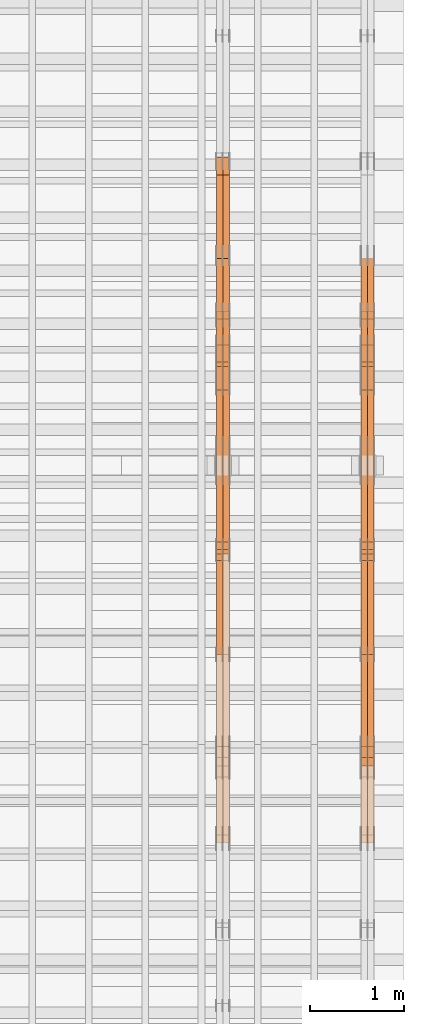
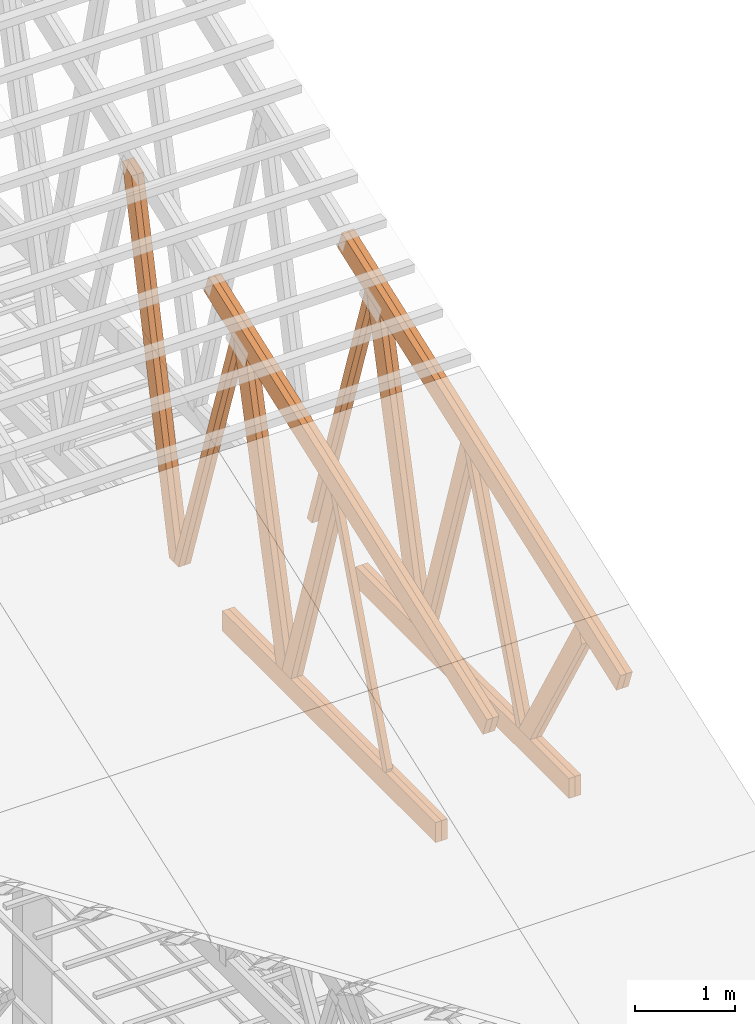
# One storey, part 55 of 189: 27 proxies.
"""IFC2X3 building model written with IfcOpenShell, lengths in millimetres."""

from ifc_helpers import new_model, entity, si_unit, converted_unit, derived_unit, direction, frame, origin, origin_2d_with_axis, place, context, subcontext, project, spatial, polyline, rectangle, outline, extrude, source, transform, mapped, material, type_object, type_shapes, element, save


model = new_model("IFC2X3")

# Units and contexts
model_context = context("Model", 3, precision=0.01, world=origin(), true_north=direction((6.12303176911189e-17, 1.0)))
body_context = subcontext(model_context, "Body", "Model", "MODEL_VIEW")
ifc_project = project(units=[si_unit("LENGTHUNIT", "METRE", prefix="MILLI"), si_unit("AREAUNIT", "SQUARE_METRE"), si_unit("VOLUMEUNIT", "CUBIC_METRE"), converted_unit("PLANEANGLEUNIT", "DEGREE", entity("IfcRatioMeasure", 0.0174532925199433), si_unit("PLANEANGLEUNIT", "RADIAN"), dimensions=[0, 0, 0, 0, 0, 0, 0]), si_unit("MASSUNIT", "GRAM", prefix="KILO"), derived_unit("MASSDENSITYUNIT", [(si_unit("MASSUNIT", "GRAM", prefix="KILO"), 1), (si_unit("LENGTHUNIT", "METRE"), -3)]), si_unit("TIMEUNIT", "SECOND"), si_unit("FREQUENCYUNIT", "HERTZ"), si_unit("THERMODYNAMICTEMPERATUREUNIT", "DEGREE_CELSIUS"), derived_unit("THERMALTRANSMITTANCEUNIT", [(si_unit("MASSUNIT", "GRAM", prefix="KILO"), 1), (si_unit("THERMODYNAMICTEMPERATUREUNIT", "KELVIN"), -1), (si_unit("TIMEUNIT", "SECOND"), -3)]), derived_unit("VOLUMETRICFLOWRATEUNIT", [(si_unit("LENGTHUNIT", "METRE"), 3), (si_unit("TIMEUNIT", "SECOND"), -1)]), si_unit("ELECTRICCURRENTUNIT", "AMPERE"), si_unit("ELECTRICVOLTAGEUNIT", "VOLT"), si_unit("POWERUNIT", "WATT"), si_unit("FORCEUNIT", "NEWTON"), si_unit("ILLUMINANCEUNIT", "LUX"), si_unit("LUMINOUSFLUXUNIT", "LUMEN"), si_unit("LUMINOUSINTENSITYUNIT", "CANDELA"), derived_unit("USERDEFINED", [(si_unit("MASSUNIT", "GRAM", prefix="KILO"), -1), (si_unit("LENGTHUNIT", "METRE"), -2), (si_unit("TIMEUNIT", "SECOND"), 3), (si_unit("LUMINOUSFLUXUNIT", "LUMEN"), 1)]), derived_unit("LINEARVELOCITYUNIT", [(si_unit("LENGTHUNIT", "METRE"), 1), (si_unit("TIMEUNIT", "SECOND"), -1)]), si_unit("PRESSUREUNIT", "PASCAL"), derived_unit("USERDEFINED", [(si_unit("LENGTHUNIT", "METRE"), -2), (si_unit("MASSUNIT", "GRAM", prefix="KILO"), 1), (si_unit("TIMEUNIT", "SECOND"), -2)])], contexts=[model_context])

# Site, building, storey
site_placement = place(None, origin())
site = spatial("IfcSite", under=ifc_project, at=site_placement, CompositionType="ELEMENT")
building_placement = place(site_placement, origin())
building = spatial("IfcBuilding", under=site, at=building_placement, CompositionType="ELEMENT")
storey_placement = place(building_placement, origin())
storey = spatial("IfcBuildingStorey", under=building, at=storey_placement, Name="Default", CompositionType="ELEMENT", Elevation=0.0)

# Proxies
ifc_material_1 = material(Name="IfcSurfaceStyle #273112")
building_element_proxy_type_1 = type_object("IfcBuildingElementProxyType", Name="T1-W7 273110", PredefinedType="NOTDEFINED", material=ifc_material_1)
shared_shape_1 = source(origin(), body_context, "Body", "SweptSolid", [
    extrude(outline(polyline([(-2158.15323194511, -47.5001976605119), (1398.58481981178, -47.5001976605119), (1473.93376219819, -0.000131511554346808), (1475.30069254941, 47.5002634162891), (-2189.66604261427, 47.5002634162891), (-2158.15323194511, -47.5001976605119)])), frame((1475.30069254941, 47.5002634162891, 0.0), z_axis=(0.0, 0.0, 1.0), x_axis=(-1.0, 0.0, 0.0)), (0.0, 0.0, 1.0), 69.9999999999998),
])
type_shapes(building_element_proxy_type_1, [shared_shape_1])
proxy_1_placement = place(building_placement, frame((49840.0, 9847.787109375, 3723.57788085937), z_axis=(-1.0, 0.0, 0.0), x_axis=(0.0, 0.314845237923105, -0.949143021971475)))
element("IfcBuildingElementProxy", 1, at=proxy_1_placement, inside=storey, type_object=building_element_proxy_type_1, material=ifc_material_1, Name="T1-W7", context=body_context, shape_type="MappedRepresentation", body=[
    mapped(shared_shape_1, transform((0.0, 0.0, 0.0), scale=1.0)),
])
ifc_material_2 = material(Name="IfcSurfaceStyle #273046")
building_element_proxy_type_2 = type_object("IfcBuildingElementProxyType", Name="T1-W7 273044", PredefinedType="NOTDEFINED", material=ifc_material_2)
shared_shape_2 = source(origin(), body_context, "Body", "SweptSolid", [
    extrude(outline(polyline([(-2158.15323194511, -47.5001976605119), (1398.58481981178, -47.5001976605119), (1473.93376219819, -0.000131511554346808), (1475.30069254941, 47.5002634162891), (-2189.66604261427, 47.5002634162891), (-2158.15323194511, -47.5001976605119)])), frame((1475.30069254941, 47.5002634162891, 0.0), z_axis=(0.0, 0.0, 1.0), x_axis=(-1.0, 0.0, 0.0)), (0.0, 0.0, 1.0), 69.9999999999998),
])
type_shapes(building_element_proxy_type_2, [shared_shape_2])
proxy_2_placement = place(building_placement, frame((49770.0, 9847.787109375, 3723.57788085937), z_axis=(-1.0, 0.0, 0.0), x_axis=(0.0, 0.314845237923105, -0.949143021971475)))
element("IfcBuildingElementProxy", 2, at=proxy_2_placement, inside=storey, type_object=building_element_proxy_type_2, material=ifc_material_2, Name="T1-W7", context=body_context, shape_type="MappedRepresentation", body=[
    mapped(shared_shape_2, transform((0.0, 0.0, 0.0), scale=1.0)),
])
ifc_material_3 = material(Name="IfcSurfaceStyle #272848")
building_element_proxy_type_3 = type_object("IfcBuildingElementProxyType", Name="T1-W1 272846", PredefinedType="NOTDEFINED", material=ifc_material_3)
shared_shape_3 = source(origin(), body_context, "Body", "SweptSolid", [
    extrude(outline(polyline([(-2144.69382208629, -109.99948311278), (1421.70798092021, -109.99948311278), (1448.88116133745, -0.000392715405943322), (1271.09900468242, 109.999679470483), (-1996.99432485378, 109.999679470483), (-2144.69382208629, -109.99948311278)])), frame((1448.88130194731, 110.000176487146, 0.0), z_axis=(0.0, 0.0, 1.0), x_axis=(-1.0, 0.0, 0.0)), (0.0, 0.0, 1.0), 69.9999999999998),
])
type_shapes(building_element_proxy_type_3, [shared_shape_3])
proxy_3_placement = place(building_placement, frame((49840.0, 8727.74270166583, 271.380182391418), z_axis=(-1.0, 0.0, 0.0), x_axis=(0.0, 0.239819839925978, 0.970817410421691)))
element("IfcBuildingElementProxy", 3, at=proxy_3_placement, inside=storey, type_object=building_element_proxy_type_3, material=ifc_material_3, Name="T1-W1", context=body_context, shape_type="MappedRepresentation", body=[
    mapped(shared_shape_3, transform((0.0, 0.0, 0.0), scale=1.0)),
])
ifc_material_4 = material(Name="IfcSurfaceStyle #272782")
building_element_proxy_type_4 = type_object("IfcBuildingElementProxyType", Name="T1-W1 272780", PredefinedType="NOTDEFINED", material=ifc_material_4)
shared_shape_4 = source(origin(), body_context, "Body", "SweptSolid", [
    extrude(outline(polyline([(-2144.69382208629, -109.99948311278), (1421.70798092021, -109.99948311278), (1448.88116133745, -0.000392715405943322), (1271.09900468242, 109.999679470483), (-1996.99432485378, 109.999679470483), (-2144.69382208629, -109.99948311278)])), frame((1448.88130194731, 110.000176487146, 0.0), z_axis=(0.0, 0.0, 1.0), x_axis=(-1.0, 0.0, 0.0)), (0.0, 0.0, 1.0), 69.9999999999998),
])
type_shapes(building_element_proxy_type_4, [shared_shape_4])
proxy_4_placement = place(building_placement, frame((49770.0, 8727.74270166583, 271.380182391418), z_axis=(-1.0, 0.0, 0.0), x_axis=(0.0, 0.239819839925978, 0.970817410421691)))
element("IfcBuildingElementProxy", 4, at=proxy_4_placement, inside=storey, type_object=building_element_proxy_type_4, material=ifc_material_4, Name="T1-W1", context=body_context, shape_type="MappedRepresentation", body=[
    mapped(shared_shape_4, transform((0.0, 0.0, 0.0), scale=1.0)),
])
ifc_material_5 = material(Name="IfcSurfaceStyle #272584")
building_element_proxy_type_5 = type_object("IfcBuildingElementProxyType", Name="T1-W4 272582", PredefinedType="NOTDEFINED", material=ifc_material_5)
shared_shape_5 = source(origin(), body_context, "Body", "SweptSolid", [
    extrude(outline(polyline([(-1688.09292256655, -85.0003489723785), (1071.44998120742, -85.0003489723785), (1178.19407811536, -0.00016040063201781), (1181.35435681367, 85.0004291726946), (-1742.9054935699, 85.0004291726946), (-1688.09292256655, -85.0003489723785)])), frame((1181.35446122976, 85.0007670757732, 0.0), z_axis=(0.0, 0.0, 1.0), x_axis=(-1.0, 0.0, 0.0)), (0.0, 0.0, 1.0), 69.9999999999998),
])
type_shapes(building_element_proxy_type_5, [shared_shape_5])
proxy_5_placement = place(building_placement, frame((49840.0, 7937.17021143291, 3028.170124945), z_axis=(-1.0, 0.0, 0.0), x_axis=(0.0, 0.306868406216492, -0.951751953644514)))
element("IfcBuildingElementProxy", 5, at=proxy_5_placement, inside=storey, type_object=building_element_proxy_type_5, material=ifc_material_5, Name="T1-W4", context=body_context, shape_type="MappedRepresentation", body=[
    mapped(shared_shape_5, transform((0.0, 0.0, 0.0), scale=1.0)),
])
ifc_material_6 = material(Name="IfcSurfaceStyle #272518")
building_element_proxy_type_6 = type_object("IfcBuildingElementProxyType", Name="T1-W4 272516", PredefinedType="NOTDEFINED", material=ifc_material_6)
shared_shape_6 = source(origin(), body_context, "Body", "SweptSolid", [
    extrude(outline(polyline([(-1688.09292256655, -85.0003489723785), (1071.44998120742, -85.0003489723785), (1178.19407811536, -0.00016040063201781), (1181.35435681367, 85.0004291726946), (-1742.9054935699, 85.0004291726946), (-1688.09292256655, -85.0003489723785)])), frame((1181.35446122976, 85.0007670757732, 0.0), z_axis=(0.0, 0.0, 1.0), x_axis=(-1.0, 0.0, 0.0)), (0.0, 0.0, 1.0), 69.9999999999998),
])
type_shapes(building_element_proxy_type_6, [shared_shape_6])
proxy_6_placement = place(building_placement, frame((49770.0, 7937.17021143291, 3028.170124945), z_axis=(-1.0, 0.0, 0.0), x_axis=(0.0, 0.306868406216492, -0.951751953644514)))
element("IfcBuildingElementProxy", 6, at=proxy_6_placement, inside=storey, type_object=building_element_proxy_type_6, material=ifc_material_6, Name="T1-W4", context=body_context, shape_type="MappedRepresentation", body=[
    mapped(shared_shape_6, transform((0.0, 0.0, 0.0), scale=1.0)),
])
ifc_material_7 = material(Name="IfcSurfaceStyle #272320")
building_element_proxy_type_7 = type_object("IfcBuildingElementProxyType", Name="T1-W8 272318", PredefinedType="NOTDEFINED", material=ifc_material_7)
shared_shape_7 = source(origin(), body_context, "Body", "SweptSolid", [
    extrude(outline(polyline([(-1781.70529904483, -47.500320228718), (1161.65050357787, -47.5003202287179), (1179.56135870849, 0.000731866266039397), (1140.6022069428, 47.4998218997103), (-1700.10877018433, 47.5000866914596), (-1781.70529904483, -47.500320228718)])), frame((1179.56135870869, 47.5007236522113, 0.0), z_axis=(0.0, 0.0, 1.0), x_axis=(-1.0, 3.74658825645258e-07, 0.0)), (0.0, 0.0, 1.0), 69.9999999999998),
])
type_shapes(building_element_proxy_type_7, [shared_shape_7])
proxy_7_placement = place(building_placement, frame((49840.0, 6723.5697965901, 261.758864533503), z_axis=(-1.0, 0.0, 0.0), x_axis=(0.0, 0.352814979177603, 0.93569310698963)))
element("IfcBuildingElementProxy", 7, at=proxy_7_placement, inside=storey, type_object=building_element_proxy_type_7, material=ifc_material_7, Name="T1-W8", context=body_context, shape_type="MappedRepresentation", body=[
    mapped(shared_shape_7, transform((0.0, 0.0, 0.0), scale=1.0)),
])
ifc_material_8 = material(Name="IfcSurfaceStyle #272254")
building_element_proxy_type_8 = type_object("IfcBuildingElementProxyType", Name="T1-W8 272252", PredefinedType="NOTDEFINED", material=ifc_material_8)
shared_shape_8 = source(origin(), body_context, "Body", "SweptSolid", [
    extrude(outline(polyline([(-1781.70529904483, -47.500320228718), (1161.65050357787, -47.5003202287179), (1179.56135870849, 0.000731866266039397), (1140.6022069428, 47.4998218997103), (-1700.10877018433, 47.5000866914596), (-1781.70529904483, -47.500320228718)])), frame((1179.56135870869, 47.5007236522113, 0.0), z_axis=(0.0, 0.0, 1.0), x_axis=(-1.0, 3.74658825645258e-07, 0.0)), (0.0, 0.0, 1.0), 69.9999999999998),
])
type_shapes(building_element_proxy_type_8, [shared_shape_8])
proxy_8_placement = place(building_placement, frame((49770.0, 6723.5697965901, 261.758864533503), z_axis=(-1.0, 0.0, 0.0), x_axis=(0.0, 0.352814979177603, 0.93569310698963)))
element("IfcBuildingElementProxy", 8, at=proxy_8_placement, inside=storey, type_object=building_element_proxy_type_8, material=ifc_material_8, Name="T1-W8", context=body_context, shape_type="MappedRepresentation", body=[
    mapped(shared_shape_8, transform((0.0, 0.0, 0.0), scale=1.0)),
])
ifc_material_9 = material(Name="IfcSurfaceStyle #272056")
building_element_proxy_type_9 = type_object("IfcBuildingElementProxyType", Name="T1-W2 272054", PredefinedType="NOTDEFINED", material=ifc_material_9)
shared_shape_9 = source(origin(), body_context, "Body", "SweptSolid", [
    extrude(outline(polyline([(-765.033104991319, -1130.91940266317), (-539.905732758898, -1130.91940266317), (493.678280567457, 660.584515081422), (452.144945212405, 783.697385511457), (359.115611970356, 817.556904733455), (-765.033104991319, -1130.91940266317)])), frame((904.774360566371, 97.5002668805543, 0.0), z_axis=(0.0, 0.0, 1.0), x_axis=(-0.499731715721184, 0.866180242387438, 0.0)), (0.0, 0.0, 1.0), 69.9999999999998),
])
type_shapes(building_element_proxy_type_9, [shared_shape_9])
proxy_9_placement = place(building_placement, frame((49840.0, 5635.28919163287, 2208.3400784451), z_axis=(-1.0, 0.0, 0.0), x_axis=(0.0, 0.5, -0.866025403784439)))
element("IfcBuildingElementProxy", 9, at=proxy_9_placement, inside=storey, type_object=building_element_proxy_type_9, material=ifc_material_9, Name="T1-W2", context=body_context, shape_type="MappedRepresentation", body=[
    mapped(shared_shape_9, transform((0.0, 0.0, 0.0), scale=1.0)),
])
ifc_material_10 = material(Name="IfcSurfaceStyle #271990")
building_element_proxy_type_10 = type_object("IfcBuildingElementProxyType", Name="T1-W2 271988", PredefinedType="NOTDEFINED", material=ifc_material_10)
shared_shape_10 = source(origin(), body_context, "Body", "SweptSolid", [
    extrude(outline(polyline([(-765.033104991319, -1130.91940266317), (-539.905732758898, -1130.91940266317), (493.678280567457, 660.584515081422), (452.144945212405, 783.697385511457), (359.115611970356, 817.556904733455), (-765.033104991319, -1130.91940266317)])), frame((904.774360566371, 97.5002668805543, 0.0), z_axis=(0.0, 0.0, 1.0), x_axis=(-0.499731715721184, 0.866180242387438, 0.0)), (0.0, 0.0, 1.0), 69.9999999999998),
])
type_shapes(building_element_proxy_type_10, [shared_shape_10])
proxy_10_placement = place(building_placement, frame((49770.0, 5635.28919163287, 2208.3400784451), z_axis=(-1.0, 0.0, 0.0), x_axis=(0.0, 0.5, -0.866025403784439)))
element("IfcBuildingElementProxy", 10, at=proxy_10_placement, inside=storey, type_object=building_element_proxy_type_10, material=ifc_material_10, Name="T1-W2", context=body_context, shape_type="MappedRepresentation", body=[
    mapped(shared_shape_10, transform((0.0, 0.0, 0.0), scale=1.0)),
])
ifc_material_11 = material(Name="IfcSurfaceStyle #269506")
building_element_proxy_type_11 = type_object("IfcBuildingElementProxyType", Name="T1-B6 269504", PredefinedType="NOTDEFINED", material=ifc_material_11)
shared_shape_11 = source(origin(), body_context, "Body", "SweptSolid", [
    extrude(rectangle(XDim=4266.763671875, YDim=245.000000000001, at=origin_2d_with_axis()), frame((2133.3818359375, 122.500000000001, 0.0), z_axis=(0.0, 0.0, 1.0), x_axis=(-1.0, 0.0, 0.0)), (0.0, 0.0, 1.0), 69.9999999999997),
])
type_shapes(building_element_proxy_type_11, [shared_shape_11])
proxy_11_placement = place(building_placement, frame((49840.0, 5762.466796875, 245.0), z_axis=(-1.0, 0.0, 0.0), x_axis=(0.0, 1.0, 0.0)))
element("IfcBuildingElementProxy", 11, at=proxy_11_placement, inside=storey, type_object=building_element_proxy_type_11, material=ifc_material_11, Name="T1-B6", context=body_context, shape_type="MappedRepresentation", body=[
    mapped(shared_shape_11, transform((0.0, 0.0, 0.0), scale=1.0)),
])
ifc_material_12 = material(Name="IfcSurfaceStyle #269449")
building_element_proxy_type_12 = type_object("IfcBuildingElementProxyType", Name="T1-B6 269447", PredefinedType="NOTDEFINED", material=ifc_material_12)
shared_shape_12 = source(origin(), body_context, "Body", "SweptSolid", [
    extrude(rectangle(XDim=4266.763671875, YDim=245.000000000001, at=origin_2d_with_axis()), frame((2133.3818359375, 122.500000000001, 0.0), z_axis=(0.0, 0.0, 1.0), x_axis=(-1.0, 0.0, 0.0)), (0.0, 0.0, 1.0), 69.9999999999997),
])
type_shapes(building_element_proxy_type_12, [shared_shape_12])
proxy_12_placement = place(building_placement, frame((49770.0, 5762.466796875, 245.0), z_axis=(-1.0, 0.0, 0.0), x_axis=(0.0, 1.0, 0.0)))
element("IfcBuildingElementProxy", 12, at=proxy_12_placement, inside=storey, type_object=building_element_proxy_type_12, material=ifc_material_12, Name="T1-B6", context=body_context, shape_type="MappedRepresentation", body=[
    mapped(shared_shape_12, transform((0.0, 0.0, 0.0), scale=1.0)),
])
ifc_material_13 = material(Name="IfcSurfaceStyle #269146")
building_element_proxy_type_13 = type_object("IfcBuildingElementProxyType", Name="T1-T1 269144", PredefinedType="NOTDEFINED", material=ifc_material_13)
shared_shape_13 = source(origin(), body_context, "Body", "SweptSolid", [
    extrude(outline(polyline([(-2964.99981923522, -122.500027388895), (2964.99982426074, -122.500027388895), (2964.99984011048, 122.500027388895), (-2964.99984513599, 122.500027388895), (-2964.99981923522, -122.500027388895)])), frame((2965.00021857317, 122.500056320695, 0.0), z_axis=(0.0, 0.0, 1.0), x_axis=(-1.0, 0.0, 0.0)), (0.0, 0.0, 1.0), 69.9999999999996),
])
type_shapes(building_element_proxy_type_13, [shared_shape_13])
proxy_13_placement = place(building_placement, frame((49840.0, 10391.0374749089, 3921.30478975487), z_axis=(-1.0, 0.0, 0.0), x_axis=(0.0, -0.939692620785908, -0.342020143325669)))
element("IfcBuildingElementProxy", 13, at=proxy_13_placement, inside=storey, type_object=building_element_proxy_type_13, material=ifc_material_13, Name="T1-T1", context=body_context, shape_type="MappedRepresentation", body=[
    mapped(shared_shape_13, transform((0.0, 0.0, 0.0), scale=1.0)),
])
ifc_material_14 = material(Name="IfcSurfaceStyle #269089")
building_element_proxy_type_14 = type_object("IfcBuildingElementProxyType", Name="T1-T1 269087", PredefinedType="NOTDEFINED", material=ifc_material_14)
shared_shape_14 = source(origin(), body_context, "Body", "SweptSolid", [
    extrude(outline(polyline([(-2964.99981923522, -122.500027388895), (2964.99982426074, -122.500027388895), (2964.99984011048, 122.500027388895), (-2964.99984513599, 122.500027388895), (-2964.99981923522, -122.500027388895)])), frame((2965.00021857317, 122.500056320695, 0.0), z_axis=(0.0, 0.0, 1.0), x_axis=(-1.0, 0.0, 0.0)), (0.0, 0.0, 1.0), 69.9999999999996),
])
type_shapes(building_element_proxy_type_14, [shared_shape_14])
proxy_14_placement = place(building_placement, frame((49770.0, 10391.0374749089, 3921.30478975487), z_axis=(-1.0, 0.0, 0.0), x_axis=(0.0, -0.939692620785908, -0.342020143325669)))
element("IfcBuildingElementProxy", 14, at=proxy_14_placement, inside=storey, type_object=building_element_proxy_type_14, material=ifc_material_14, Name="T1-T1", context=body_context, shape_type="MappedRepresentation", body=[
    mapped(shared_shape_14, transform((0.0, 0.0, 0.0), scale=1.0)),
])
ifc_material_15 = material(Name="IfcSurfaceStyle #257586")
building_element_proxy_type_15 = type_object("IfcBuildingElementProxyType", Name="T1-W3 257584", PredefinedType="NOTDEFINED", material=ifc_material_15)
shared_shape_15 = source(origin(), body_context, "Body", "SweptSolid", [
    extrude(outline(polyline([(-2625.55080717397, -84.9998286237256), (1749.48871563991, -84.9998286237256), (1768.20584427244, 0.000602085469291858), (1625.445846867, 85.0000405971208), (-2517.58959960538, 84.9990145648612), (-2625.55080717397, -84.9998286237256)])), frame((1768.20584427244, 85.0000405971208, 0.0), z_axis=(0.0, 0.0, 1.0), x_axis=(-1.0, 0.0, 0.0)), (0.0, 0.0, 1.0), 69.9999999999997),
])
type_shapes(building_element_proxy_type_15, [shared_shape_15])
proxy_15_placement = place(building_placement, frame((48300.0, 10918.6728403286, 263.278932236374), z_axis=(-1.0, 0.0, 0.0), x_axis=(0.0, 0.215047682154604, 0.976603550269982)))
element("IfcBuildingElementProxy", 15, at=proxy_15_placement, inside=storey, type_object=building_element_proxy_type_15, material=ifc_material_15, Name="T1-W3", context=body_context, shape_type="MappedRepresentation", body=[
    mapped(shared_shape_15, transform((0.0, 0.0, 0.0), scale=1.0)),
])
ifc_material_16 = material(Name="IfcSurfaceStyle #257520")
building_element_proxy_type_16 = type_object("IfcBuildingElementProxyType", Name="T1-W3 257518", PredefinedType="NOTDEFINED", material=ifc_material_16)
shared_shape_16 = source(origin(), body_context, "Body", "SweptSolid", [
    extrude(outline(polyline([(-2625.55080717397, -84.9998286237256), (1749.48871563991, -84.9998286237256), (1768.20584427244, 0.000602085469291858), (1625.445846867, 85.0000405971208), (-2517.58959960538, 84.9990145648612), (-2625.55080717397, -84.9998286237256)])), frame((1768.20584427244, 85.0000405971208, 0.0), z_axis=(0.0, 0.0, 1.0), x_axis=(-1.0, 0.0, 0.0)), (0.0, 0.0, 1.0), 69.9999999999997),
])
type_shapes(building_element_proxy_type_16, [shared_shape_16])
proxy_16_placement = place(building_placement, frame((48230.0, 10918.6728403286, 263.278932236374), z_axis=(-1.0, 0.0, 0.0), x_axis=(0.0, 0.215047682154604, 0.976603550269982)))
element("IfcBuildingElementProxy", 16, at=proxy_16_placement, inside=storey, type_object=building_element_proxy_type_16, material=ifc_material_16, Name="T1-W3", context=body_context, shape_type="MappedRepresentation", body=[
    mapped(shared_shape_16, transform((0.0, 0.0, 0.0), scale=1.0)),
])
ifc_material_17 = material(Name="IfcSurfaceStyle #257322")
building_element_proxy_type_17 = type_object("IfcBuildingElementProxyType", Name="T1-W7 257320", PredefinedType="NOTDEFINED", material=ifc_material_17)
shared_shape_17 = source(origin(), body_context, "Body", "SweptSolid", [
    extrude(outline(polyline([(-2158.15323194511, -47.5001976605119), (1398.58481981178, -47.5001976605119), (1473.93376219819, -0.000131511554346808), (1475.30069254941, 47.5002634162891), (-2189.66604261427, 47.5002634162891), (-2158.15323194511, -47.5001976605119)])), frame((1475.30069254941, 47.5002634162891, 0.0), z_axis=(0.0, 0.0, 1.0), x_axis=(-1.0, 0.0, 0.0)), (0.0, 0.0, 1.0), 69.9999999999998),
])
type_shapes(building_element_proxy_type_17, [shared_shape_17])
proxy_17_placement = place(building_placement, frame((48300.0, 9847.787109375, 3723.57788085937), z_axis=(-1.0, 0.0, 0.0), x_axis=(0.0, 0.314845237923105, -0.949143021971475)))
element("IfcBuildingElementProxy", 17, at=proxy_17_placement, inside=storey, type_object=building_element_proxy_type_17, material=ifc_material_17, Name="T1-W7", context=body_context, shape_type="MappedRepresentation", body=[
    mapped(shared_shape_17, transform((0.0, 0.0, 0.0), scale=1.0)),
])
ifc_material_18 = material(Name="IfcSurfaceStyle #257256")
building_element_proxy_type_18 = type_object("IfcBuildingElementProxyType", Name="T1-W7 257254", PredefinedType="NOTDEFINED", material=ifc_material_18)
shared_shape_18 = source(origin(), body_context, "Body", "SweptSolid", [
    extrude(outline(polyline([(-2158.15323194511, -47.5001976605119), (1398.58481981178, -47.5001976605119), (1473.93376219819, -0.000131511554346808), (1475.30069254941, 47.5002634162891), (-2189.66604261427, 47.5002634162891), (-2158.15323194511, -47.5001976605119)])), frame((1475.30069254941, 47.5002634162891, 0.0), z_axis=(0.0, 0.0, 1.0), x_axis=(-1.0, 0.0, 0.0)), (0.0, 0.0, 1.0), 69.9999999999998),
])
type_shapes(building_element_proxy_type_18, [shared_shape_18])
proxy_18_placement = place(building_placement, frame((48230.0, 9847.787109375, 3723.57788085937), z_axis=(-1.0, 0.0, 0.0), x_axis=(0.0, 0.314845237923105, -0.949143021971475)))
element("IfcBuildingElementProxy", 18, at=proxy_18_placement, inside=storey, type_object=building_element_proxy_type_18, material=ifc_material_18, Name="T1-W7", context=body_context, shape_type="MappedRepresentation", body=[
    mapped(shared_shape_18, transform((0.0, 0.0, 0.0), scale=1.0)),
])
ifc_material_19 = material(Name="IfcSurfaceStyle #257058")
building_element_proxy_type_19 = type_object("IfcBuildingElementProxyType", Name="T1-W1 257056", PredefinedType="NOTDEFINED", material=ifc_material_19)
shared_shape_19 = source(origin(), body_context, "Body", "SweptSolid", [
    extrude(outline(polyline([(-2144.69382208629, -109.99948311278), (1421.70798092021, -109.99948311278), (1448.88116133745, -0.000392715405943322), (1271.09900468242, 109.999679470483), (-1996.99432485378, 109.999679470483), (-2144.69382208629, -109.99948311278)])), frame((1448.88130194731, 110.000176487146, 0.0), z_axis=(0.0, 0.0, 1.0), x_axis=(-1.0, 0.0, 0.0)), (0.0, 0.0, 1.0), 69.9999999999998),
])
type_shapes(building_element_proxy_type_19, [shared_shape_19])
proxy_19_placement = place(building_placement, frame((48300.0, 8727.74270166583, 271.380182391418), z_axis=(-1.0, 0.0, 0.0), x_axis=(0.0, 0.239819839925978, 0.970817410421691)))
element("IfcBuildingElementProxy", 19, at=proxy_19_placement, inside=storey, type_object=building_element_proxy_type_19, material=ifc_material_19, Name="T1-W1", context=body_context, shape_type="MappedRepresentation", body=[
    mapped(shared_shape_19, transform((0.0, 0.0, 0.0), scale=1.0)),
])
ifc_material_20 = material(Name="IfcSurfaceStyle #256992")
building_element_proxy_type_20 = type_object("IfcBuildingElementProxyType", Name="T1-W1 256990", PredefinedType="NOTDEFINED", material=ifc_material_20)
shared_shape_20 = source(origin(), body_context, "Body", "SweptSolid", [
    extrude(outline(polyline([(-2144.69382208629, -109.99948311278), (1421.70798092021, -109.99948311278), (1448.88116133745, -0.000392715405943322), (1271.09900468242, 109.999679470483), (-1996.99432485378, 109.999679470483), (-2144.69382208629, -109.99948311278)])), frame((1448.88130194731, 110.000176487146, 0.0), z_axis=(0.0, 0.0, 1.0), x_axis=(-1.0, 0.0, 0.0)), (0.0, 0.0, 1.0), 69.9999999999998),
])
type_shapes(building_element_proxy_type_20, [shared_shape_20])
proxy_20_placement = place(building_placement, frame((48230.0, 8727.74270166583, 271.380182391418), z_axis=(-1.0, 0.0, 0.0), x_axis=(0.0, 0.239819839925978, 0.970817410421691)))
element("IfcBuildingElementProxy", 20, at=proxy_20_placement, inside=storey, type_object=building_element_proxy_type_20, material=ifc_material_20, Name="T1-W1", context=body_context, shape_type="MappedRepresentation", body=[
    mapped(shared_shape_20, transform((0.0, 0.0, 0.0), scale=1.0)),
])
ifc_material_21 = material(Name="IfcSurfaceStyle #256794")
building_element_proxy_type_21 = type_object("IfcBuildingElementProxyType", Name="T1-W4 256792", PredefinedType="NOTDEFINED", material=ifc_material_21)
shared_shape_21 = source(origin(), body_context, "Body", "SweptSolid", [
    extrude(outline(polyline([(-1688.09292256655, -85.0003489723785), (1071.44998120742, -85.0003489723785), (1178.19407811536, -0.00016040063201781), (1181.35435681367, 85.0004291726946), (-1742.9054935699, 85.0004291726946), (-1688.09292256655, -85.0003489723785)])), frame((1181.35446122976, 85.0007670757732, 0.0), z_axis=(0.0, 0.0, 1.0), x_axis=(-1.0, 0.0, 0.0)), (0.0, 0.0, 1.0), 69.9999999999998),
])
type_shapes(building_element_proxy_type_21, [shared_shape_21])
proxy_21_placement = place(building_placement, frame((48300.0, 7937.17021143291, 3028.170124945), z_axis=(-1.0, 0.0, 0.0), x_axis=(0.0, 0.306868406216492, -0.951751953644514)))
element("IfcBuildingElementProxy", 21, at=proxy_21_placement, inside=storey, type_object=building_element_proxy_type_21, material=ifc_material_21, Name="T1-W4", context=body_context, shape_type="MappedRepresentation", body=[
    mapped(shared_shape_21, transform((0.0, 0.0, 0.0), scale=1.0)),
])
ifc_material_22 = material(Name="IfcSurfaceStyle #256728")
building_element_proxy_type_22 = type_object("IfcBuildingElementProxyType", Name="T1-W4 256726", PredefinedType="NOTDEFINED", material=ifc_material_22)
shared_shape_22 = source(origin(), body_context, "Body", "SweptSolid", [
    extrude(outline(polyline([(-1688.09292256655, -85.0003489723785), (1071.44998120742, -85.0003489723785), (1178.19407811536, -0.00016040063201781), (1181.35435681367, 85.0004291726946), (-1742.9054935699, 85.0004291726946), (-1688.09292256655, -85.0003489723785)])), frame((1181.35446122976, 85.0007670757732, 0.0), z_axis=(0.0, 0.0, 1.0), x_axis=(-1.0, 0.0, 0.0)), (0.0, 0.0, 1.0), 69.9999999999998),
])
type_shapes(building_element_proxy_type_22, [shared_shape_22])
proxy_22_placement = place(building_placement, frame((48230.0, 7937.17021143291, 3028.170124945), z_axis=(-1.0, 0.0, 0.0), x_axis=(0.0, 0.306868406216492, -0.951751953644514)))
element("IfcBuildingElementProxy", 22, at=proxy_22_placement, inside=storey, type_object=building_element_proxy_type_22, material=ifc_material_22, Name="T1-W4", context=body_context, shape_type="MappedRepresentation", body=[
    mapped(shared_shape_22, transform((0.0, 0.0, 0.0), scale=1.0)),
])
ifc_material_23 = material(Name="IfcSurfaceStyle #256464")
building_element_proxy_type_23 = type_object("IfcBuildingElementProxyType", Name="T1-W8 256462", PredefinedType="NOTDEFINED", material=ifc_material_23)
shared_shape_23 = source(origin(), body_context, "Body", "SweptSolid", [
    extrude(outline(polyline([(-1781.70529904483, -47.500320228718), (1161.65050357787, -47.5003202287179), (1179.56135870849, 0.000731866266039397), (1140.6022069428, 47.4998218997103), (-1700.10877018433, 47.5000866914596), (-1781.70529904483, -47.500320228718)])), frame((1179.56135870869, 47.5007236522113, 0.0), z_axis=(0.0, 0.0, 1.0), x_axis=(-1.0, 3.74658825645258e-07, 0.0)), (0.0, 0.0, 1.0), 69.9999999999998),
])
type_shapes(building_element_proxy_type_23, [shared_shape_23])
proxy_23_placement = place(building_placement, frame((48230.0, 6723.5697965901, 261.758864533503), z_axis=(-1.0, 0.0, 0.0), x_axis=(0.0, 0.352814979177603, 0.93569310698963)))
element("IfcBuildingElementProxy", 23, at=proxy_23_placement, inside=storey, type_object=building_element_proxy_type_23, material=ifc_material_23, Name="T1-W8", context=body_context, shape_type="MappedRepresentation", body=[
    mapped(shared_shape_23, transform((0.0, 0.0, 0.0), scale=1.0)),
])
ifc_material_24 = material(Name="IfcSurfaceStyle #253716")
building_element_proxy_type_24 = type_object("IfcBuildingElementProxyType", Name="T1-B6 253714", PredefinedType="NOTDEFINED", material=ifc_material_24)
shared_shape_24 = source(origin(), body_context, "Body", "SweptSolid", [
    extrude(rectangle(XDim=4266.763671875, YDim=245.000000000001, at=origin_2d_with_axis()), frame((2133.3818359375, 122.500000000001, 0.0), z_axis=(0.0, 0.0, 1.0), x_axis=(-1.0, 0.0, 0.0)), (0.0, 0.0, 1.0), 69.9999999999997),
])
type_shapes(building_element_proxy_type_24, [shared_shape_24])
proxy_24_placement = place(building_placement, frame((48300.0, 5762.466796875, 245.0), z_axis=(-1.0, 0.0, 0.0), x_axis=(0.0, 1.0, 0.0)))
element("IfcBuildingElementProxy", 24, at=proxy_24_placement, inside=storey, type_object=building_element_proxy_type_24, material=ifc_material_24, Name="T1-B6", context=body_context, shape_type="MappedRepresentation", body=[
    mapped(shared_shape_24, transform((0.0, 0.0, 0.0), scale=1.0)),
])
ifc_material_25 = material(Name="IfcSurfaceStyle #253659")
building_element_proxy_type_25 = type_object("IfcBuildingElementProxyType", Name="T1-B6 253657", PredefinedType="NOTDEFINED", material=ifc_material_25)
shared_shape_25 = source(origin(), body_context, "Body", "SweptSolid", [
    extrude(rectangle(XDim=4266.763671875, YDim=245.000000000001, at=origin_2d_with_axis()), frame((2133.3818359375, 122.500000000001, 0.0), z_axis=(0.0, 0.0, 1.0), x_axis=(-1.0, 0.0, 0.0)), (0.0, 0.0, 1.0), 69.9999999999997),
])
type_shapes(building_element_proxy_type_25, [shared_shape_25])
proxy_25_placement = place(building_placement, frame((48230.0, 5762.466796875, 245.0), z_axis=(-1.0, 0.0, 0.0), x_axis=(0.0, 1.0, 0.0)))
element("IfcBuildingElementProxy", 25, at=proxy_25_placement, inside=storey, type_object=building_element_proxy_type_25, material=ifc_material_25, Name="T1-B6", context=body_context, shape_type="MappedRepresentation", body=[
    mapped(shared_shape_25, transform((0.0, 0.0, 0.0), scale=1.0)),
])
ifc_material_26 = material(Name="IfcSurfaceStyle #253356")
building_element_proxy_type_26 = type_object("IfcBuildingElementProxyType", Name="T1-T1 253354", PredefinedType="NOTDEFINED", material=ifc_material_26)
shared_shape_26 = source(origin(), body_context, "Body", "SweptSolid", [
    extrude(outline(polyline([(-2964.99981923522, -122.500027388895), (2964.99982426074, -122.500027388895), (2964.99984011048, 122.500027388895), (-2964.99984513599, 122.500027388895), (-2964.99981923522, -122.500027388895)])), frame((2965.00021857317, 122.500056320695, 0.0), z_axis=(0.0, 0.0, 1.0), x_axis=(-1.0, 0.0, 0.0)), (0.0, 0.0, 1.0), 69.9999999999996),
])
type_shapes(building_element_proxy_type_26, [shared_shape_26])
proxy_26_placement = place(building_placement, frame((48300.0, 10391.0374749089, 3921.30478975487), z_axis=(-1.0, 0.0, 0.0), x_axis=(0.0, -0.939692620785908, -0.342020143325669)))
element("IfcBuildingElementProxy", 26, at=proxy_26_placement, inside=storey, type_object=building_element_proxy_type_26, material=ifc_material_26, Name="T1-T1", context=body_context, shape_type="MappedRepresentation", body=[
    mapped(shared_shape_26, transform((0.0, 0.0, 0.0), scale=1.0)),
])
ifc_material_27 = material(Name="IfcSurfaceStyle #253299")
building_element_proxy_type_27 = type_object("IfcBuildingElementProxyType", Name="T1-T1 253297", PredefinedType="NOTDEFINED", material=ifc_material_27)
shared_shape_27 = source(origin(), body_context, "Body", "SweptSolid", [
    extrude(outline(polyline([(-2964.99981923522, -122.500027388895), (2964.99982426074, -122.500027388895), (2964.99984011048, 122.500027388895), (-2964.99984513599, 122.500027388895), (-2964.99981923522, -122.500027388895)])), frame((2965.00021857317, 122.500056320695, 0.0), z_axis=(0.0, 0.0, 1.0), x_axis=(-1.0, 0.0, 0.0)), (0.0, 0.0, 1.0), 69.9999999999996),
])
type_shapes(building_element_proxy_type_27, [shared_shape_27])
proxy_27_placement = place(building_placement, frame((48230.0, 10391.0374749089, 3921.30478975487), z_axis=(-1.0, 0.0, 0.0), x_axis=(0.0, -0.939692620785908, -0.342020143325669)))
element("IfcBuildingElementProxy", 27, at=proxy_27_placement, inside=storey, type_object=building_element_proxy_type_27, material=ifc_material_27, Name="T1-T1", context=body_context, shape_type="MappedRepresentation", body=[
    mapped(shared_shape_27, transform((0.0, 0.0, 0.0), scale=1.0)),
])

save(model, "model.ifc")
